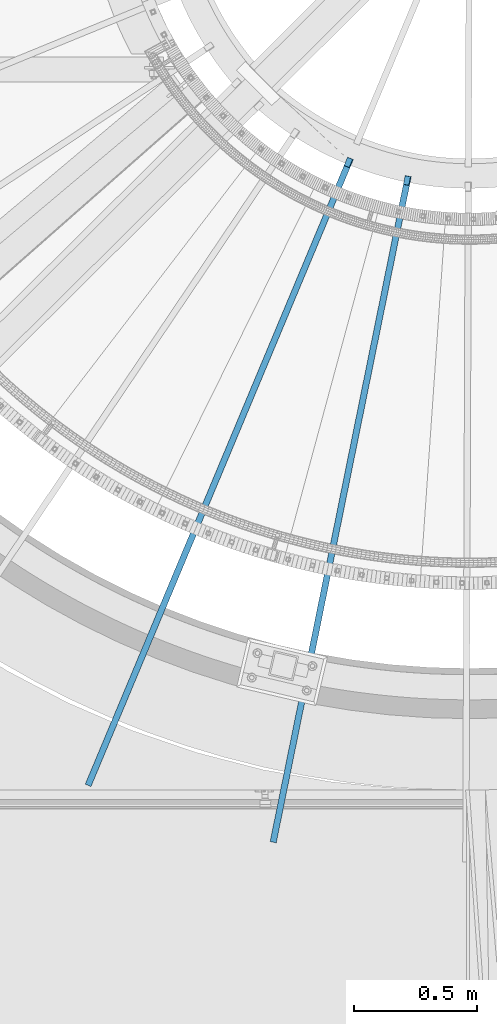
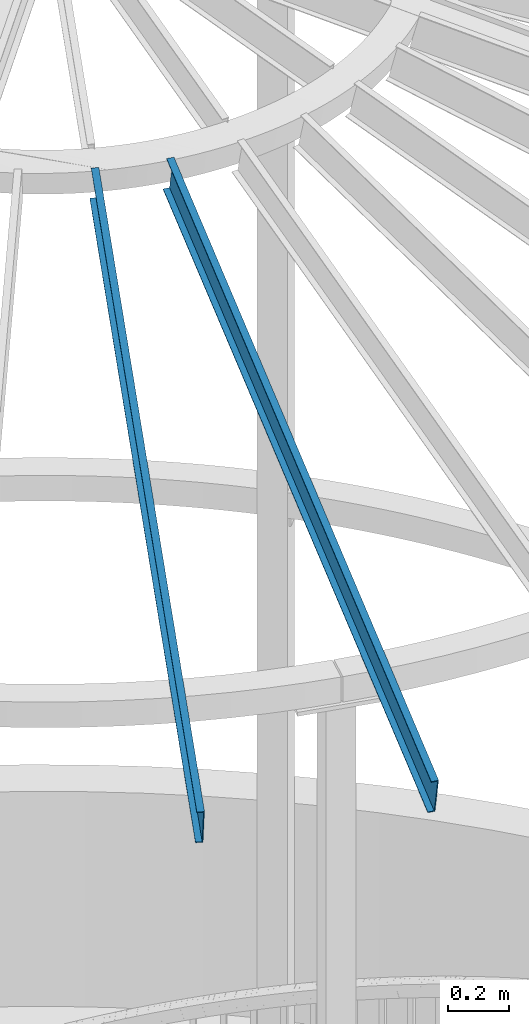
# One storey, part 339 of 975: 2 beams.
"""IFC2X3 building model written with IfcOpenShell, lengths in millimetres."""

from ifc_helpers import new_model, si_unit, frame, origin_with_axes, place, context, subcontext, project, spatial, faceted_brep, material, type_object, element, save


model = new_model("IFC2X3")

# Units and contexts
model_context = context("Model", 3, precision=1e-05, world=origin_with_axes())
body_context = subcontext(model_context, "Body", "Model", "MODEL_VIEW")
ifc_project = project(units=[si_unit("LENGTHUNIT", "METRE", prefix="MILLI"), si_unit("AREAUNIT", "SQUARE_METRE"), si_unit("VOLUMEUNIT", "CUBIC_METRE"), si_unit("MASSUNIT", "GRAM", prefix="KILO"), si_unit("TIMEUNIT", "SECOND"), si_unit("PLANEANGLEUNIT", "RADIAN"), si_unit("SOLIDANGLEUNIT", "STERADIAN"), si_unit("THERMODYNAMICTEMPERATUREUNIT", "DEGREE_CELSIUS"), si_unit("LUMINOUSINTENSITYUNIT", "LUMEN")], contexts=[model_context])

# Site, building, storey
site_placement = place(None, origin_with_axes())
site = spatial("IfcSite", under=ifc_project, at=site_placement, CompositionType="ELEMENT")
building_placement = place(site_placement, origin_with_axes())
building = spatial("IfcBuilding", under=site, at=building_placement, Name="Undefined", CompositionType="ELEMENT")
storey_placement = place(building_placement, origin_with_axes())
storey = spatial("IfcBuildingStorey", under=building, at=storey_placement, Name="Undefined", CompositionType="ELEMENT", Elevation=0.0)

# Beams
ifc_material = material(Name="STEEL/Zero_Density")
beam_type = type_object("IfcBeamType", PredefinedType="NOTDEFINED")
for number, where, z_axis, x_axis, name in (
    (1, (34246.2082242636, 2235.97091408286, 8885.0313138005), (-0.0936371633068046, -0.223737955733079, 0.970140922140818), (-0.374538296949224, -0.894927076878677, -0.242541936967119), "STUD"),
    (2, (34483.3837481827, 2163.14557979555, 8885.0313138005), (-0.0481888419808747, -0.237706597905655, 0.97014092214516), (-0.192750037960069, -0.950800100803031, -0.242541936949754), "STUD"),
):
    element("IfcBeam", number, at=place(storey_placement, frame(where, z_axis=z_axis, x_axis=x_axis)), inside=storey, type_object=beam_type, material=ifc_material, Name=name, context=body_context, shape_type="Brep", body=[
        faceted_brep([(-1.67347025126219e-10, 12.6999999998588, -76.2000000000985), (1.96450855582952e-10, 12.7000000001644, 76.2000000001021), (2798.98467503002, 12.7000000041553, 76.2000000028588), (2798.98467502966, 12.7000000038533, -76.1999999973427), (1.74622982740402e-10, -12.6999999998661, 76.2000000000985), (2798.98467503, -12.6999999958753, 76.2000000028534), (1.67347025126219e-10, -12.6999999998698, 73.0250000000947), (2798.98467502999, -12.6999999958789, 73.0250000028504), (1.89174897968769e-10, 9.52500000015425, 73.0250000000974), (2798.98467503001, 9.52500000414511, 73.0250000028532), (-1.60071067512035e-10, 9.52499999986321, -73.0250000000938), (2798.98467502966, 9.52500000385407, -73.0249999973398), (-1.81898940354586e-10, -12.7000000001608, -73.0250000000965), (2798.98467502964, -12.6999999961699, -73.0249999973416), (-1.92812876775861e-10, -12.7000000001717, -76.2000000001003), (2798.98467502963, -12.6999999961772, -76.1999999973455)], [[[0, 1, 2, 3]], [[1, 4, 5, 2]], [[4, 6, 7, 5]], [[6, 8, 9, 7]], [[8, 10, 11, 9]], [[10, 12, 13, 11]], [[12, 14, 15, 13]], [[14, 0, 3, 15]], [[5, 7, 9, 11, 13, 15, 3, 2]], [[14, 12, 10, 8, 6, 4, 1, 0]]]),
    ])

save(model, "model.ifc")
